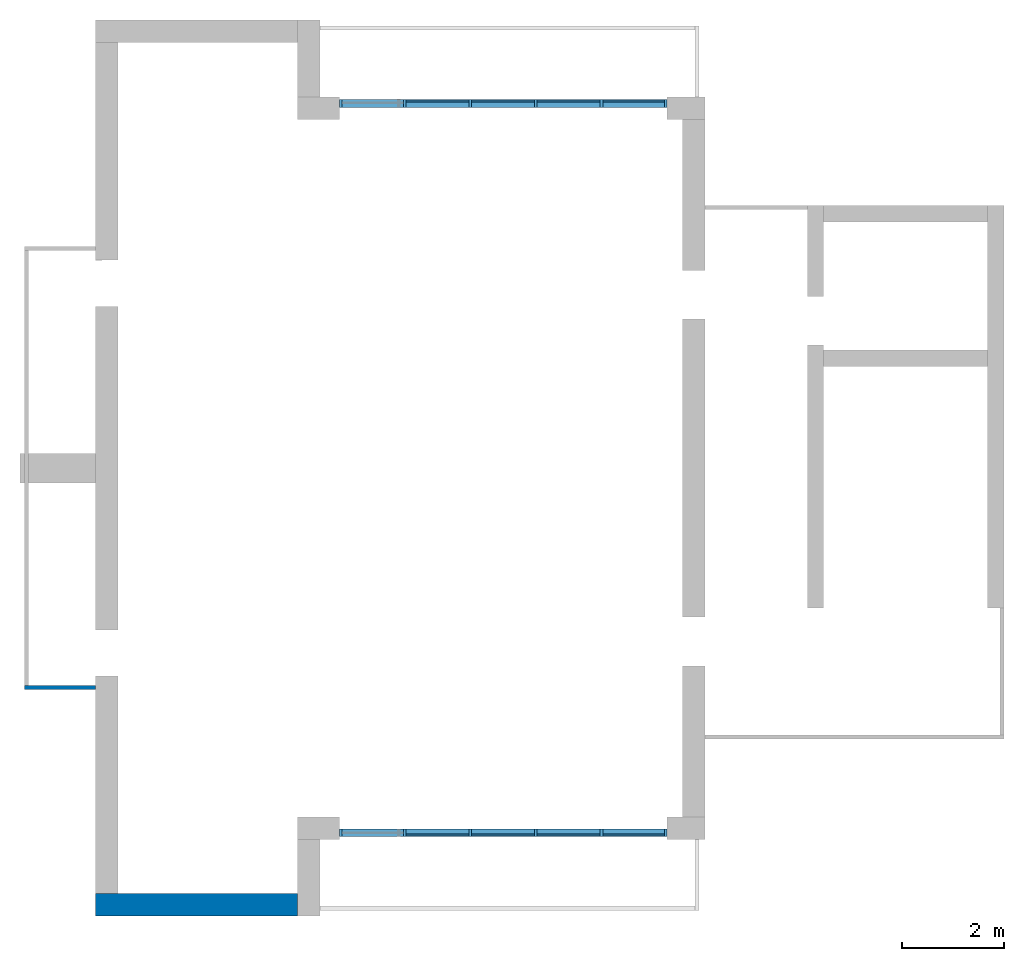
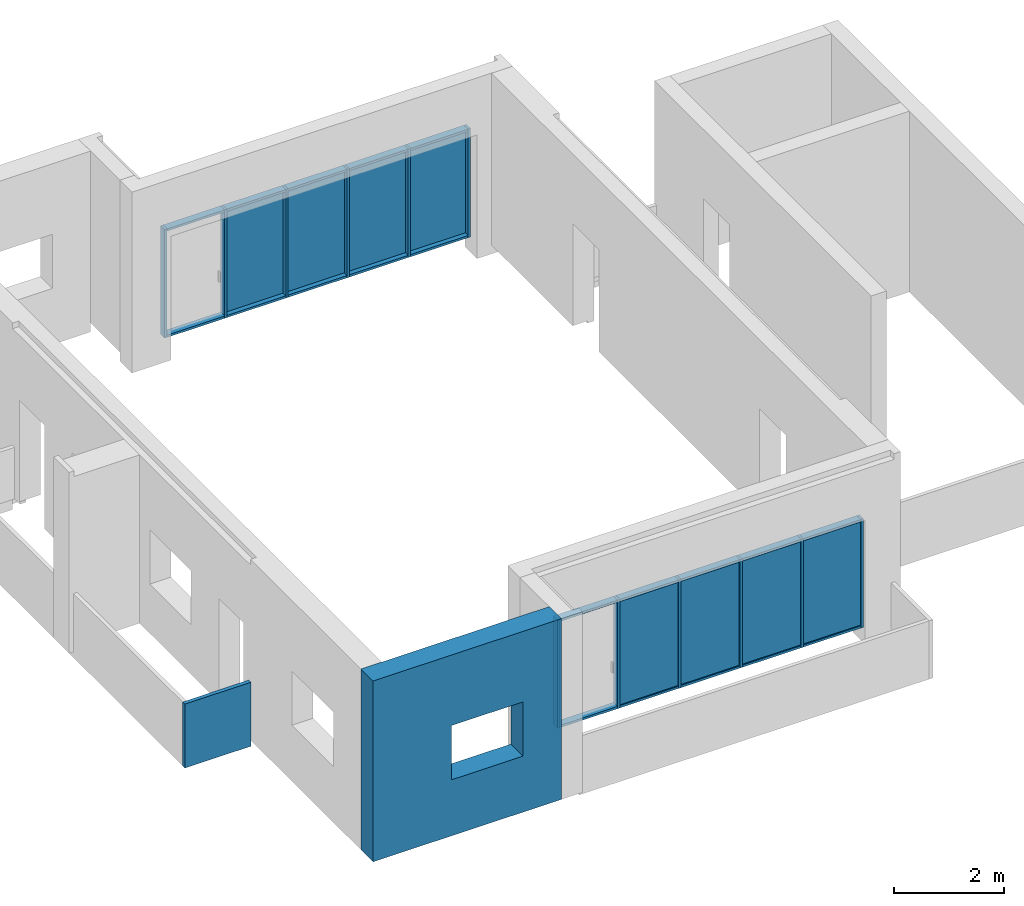
# One storey, part 1 of 4: 32 members, 8 plates, 2 walls, 1 opening, 2 elements without a shape of their own.
"""IFC2X3 building model written with IfcOpenShell, lengths in millimetres."""

from ifc_helpers import new_model, entity, si_unit, converted_unit, derived_unit, direction, frame, frame_2d, origin, origin_2d_with_axis, place, context, subcontext, project, spatial, polyline, rectangle, extrude, clip, bounded_halfspace, source, transform, mapped, material, layer, layer_set, layer_usage, type_object, type_shapes, element, aggregate, save


model = new_model("IFC2X3")

# Units and contexts
model_context = context("Model", 3, precision=0.01, world=origin(), true_north=direction((6.12303176911189e-17, 1.0)))
body_context = subcontext(model_context, "Body", "Model", "MODEL_VIEW")
ifc_project = project(units=[si_unit("LENGTHUNIT", "METRE", prefix="MILLI"), si_unit("AREAUNIT", "SQUARE_METRE"), si_unit("VOLUMEUNIT", "CUBIC_METRE"), converted_unit("PLANEANGLEUNIT", "DEGREE", entity("IfcRatioMeasure", 0.0174532925199433), si_unit("PLANEANGLEUNIT", "RADIAN"), dimensions=[0, 0, 0, 0, 0, 0, 0]), si_unit("MASSUNIT", "GRAM", prefix="KILO"), derived_unit("MASSDENSITYUNIT", [(si_unit("MASSUNIT", "GRAM", prefix="KILO"), 1), (si_unit("LENGTHUNIT", "METRE"), -3)]), si_unit("TIMEUNIT", "SECOND"), si_unit("FREQUENCYUNIT", "HERTZ"), si_unit("THERMODYNAMICTEMPERATUREUNIT", "DEGREE_CELSIUS"), derived_unit("THERMALTRANSMITTANCEUNIT", [(si_unit("MASSUNIT", "GRAM", prefix="KILO"), 1), (si_unit("THERMODYNAMICTEMPERATUREUNIT", "KELVIN"), -1), (si_unit("TIMEUNIT", "SECOND"), -3)]), derived_unit("VOLUMETRICFLOWRATEUNIT", [(si_unit("LENGTHUNIT", "METRE"), 3), (si_unit("TIMEUNIT", "SECOND"), -1)]), si_unit("ELECTRICCURRENTUNIT", "AMPERE"), si_unit("ELECTRICVOLTAGEUNIT", "VOLT"), si_unit("POWERUNIT", "WATT"), si_unit("FORCEUNIT", "NEWTON", prefix="KILO"), si_unit("ILLUMINANCEUNIT", "LUX"), si_unit("LUMINOUSFLUXUNIT", "LUMEN"), si_unit("LUMINOUSINTENSITYUNIT", "CANDELA"), derived_unit("USERDEFINED", [(si_unit("MASSUNIT", "GRAM", prefix="KILO"), -1), (si_unit("LENGTHUNIT", "METRE"), -2), (si_unit("TIMEUNIT", "SECOND"), 3), (si_unit("LUMINOUSFLUXUNIT", "LUMEN"), 1)]), derived_unit("LINEARVELOCITYUNIT", [(si_unit("LENGTHUNIT", "METRE"), 1), (si_unit("TIMEUNIT", "SECOND"), -1)]), si_unit("PRESSUREUNIT", "PASCAL"), derived_unit("USERDEFINED", [(si_unit("LENGTHUNIT", "METRE"), -2), (si_unit("MASSUNIT", "GRAM", prefix="KILO"), 1), (si_unit("TIMEUNIT", "SECOND"), -2)])], contexts=[model_context])

# Site, building, storey
site_placement = place(None, origin())
site = spatial("IfcSite", under=ifc_project, at=site_placement, CompositionType="ELEMENT")
building_placement = place(site_placement, origin())
building = spatial("IfcBuilding", under=site, at=building_placement, CompositionType="ELEMENT")
storey_placement = place(building_placement, frame((0.0, 0.0, 4000.0)))
storey = spatial("IfcBuildingStorey", under=building, at=storey_placement, Name="01 Level", CompositionType="ELEMENT", Elevation=4000.0)

# Curtain wall, members
curtain_wall_type = type_object("IfcCurtainWallType", Name="Curtain Wall", PredefinedType="NOTDEFINED")
curtain_wall_1_placement = place(storey_placement, frame((0.0, 0.0, -4000.0)))
curtain_wall_1 = element("IfcCurtainWall", 1, at=curtain_wall_1_placement, inside=storey, type_object=curtain_wall_type, Name="Curtain Wall", ObjectType="Curtain Wall")
ifc_material_1 = material(Name="Aluminium")
member_type_1 = type_object("IfcMemberType", Name="50 x 150mm", PredefinedType="MEMBER")
shared_shape_1 = source(origin(), body_context, "Body", "SweptSolid", [
    extrude(rectangle(XDim=150.0, YDim=50.0, at=origin_2d_with_axis()), frame((-25.0, 0.0, -2400.0), z_axis=(0.0, 0.0, 1.0), x_axis=(0.0, -1.0, 0.0)), (0.0, 0.0, 1.0), 2400.0),
])
type_shapes(member_type_1, [shared_shape_1])
member_1_placement = place(storey_placement, frame((21803.4900708518, -75951.2395851399, 0.0), z_axis=(0.0, 0.0, -1.0), x_axis=(-1.0, 0.0, 0.0)))
member_1 = element("IfcMember", 2, at=member_1_placement, type_object=member_type_1, material=ifc_material_1, Name="Rectangular Mullion:50 x 150mm", ObjectType="Rectangular Mullion:50 x 150mm", context=body_context, shape_type="MappedRepresentation", body=[
    mapped(shared_shape_1, transform((0.0, 0.0, 0.0), scale=1.0)),
])
member_type_2 = type_object("IfcMemberType", Name="50 x 150mm", PredefinedType="MEMBER")
shared_shape_2 = source(origin(), body_context, "Body", "SweptSolid", [
    extrude(rectangle(XDim=150.0, YDim=50.0, at=origin_2d_with_axis()), frame((0.0, 0.0, -2400.0), z_axis=(0.0, 0.0, 1.0), x_axis=(0.0, -1.0, 0.0)), (0.0, 0.0, 1.0), 2400.0),
])
type_shapes(member_type_2, [shared_shape_2])
member_2_placement = place(storey_placement, frame((23083.4900708518, -75951.2395851399, 0.0), z_axis=(0.0, 0.0, -1.0), x_axis=(-1.0, 0.0, 0.0)))
member_2 = element("IfcMember", 3, at=member_2_placement, type_object=member_type_2, material=ifc_material_1, Name="Rectangular Mullion:50 x 150mm", ObjectType="Rectangular Mullion:50 x 150mm", context=body_context, shape_type="MappedRepresentation", body=[
    mapped(shared_shape_2, transform((0.0, 0.0, 0.0), scale=1.0)),
])
member_3_placement = place(storey_placement, frame((24363.4900708518, -75951.2395851399, 0.0), z_axis=(0.0, 0.0, -1.0), x_axis=(-1.0, 0.0, 0.0)))
member_3 = element("IfcMember", 4, at=member_3_placement, type_object=member_type_2, material=ifc_material_1, Name="Rectangular Mullion:50 x 150mm", ObjectType="Rectangular Mullion:50 x 150mm", context=body_context, shape_type="MappedRepresentation", body=[
    mapped(shared_shape_2, transform((0.0, 0.0, 0.0), scale=1.0)),
])
member_4_placement = place(storey_placement, frame((25643.4900708518, -75951.2395851399, 0.0), z_axis=(0.0, 0.0, -1.0), x_axis=(-1.0, 0.0, 0.0)))
member_4 = element("IfcMember", 5, at=member_4_placement, type_object=member_type_2, material=ifc_material_1, Name="Rectangular Mullion:50 x 150mm", ObjectType="Rectangular Mullion:50 x 150mm", context=body_context, shape_type="MappedRepresentation", body=[
    mapped(shared_shape_2, transform((0.0, 0.0, 0.0), scale=1.0)),
])
member_5_placement = place(storey_placement, frame((26923.4900708518, -75951.2395851399, 0.0), z_axis=(0.0, 0.0, -1.0), x_axis=(-1.0, 0.0, 0.0)))
member_5 = element("IfcMember", 6, at=member_5_placement, type_object=member_type_2, material=ifc_material_1, Name="Rectangular Mullion:50 x 150mm", ObjectType="Rectangular Mullion:50 x 150mm", context=body_context, shape_type="MappedRepresentation", body=[
    mapped(shared_shape_2, transform((0.0, 0.0, 0.0), scale=1.0)),
])
member_type_3 = type_object("IfcMemberType", Name="50 x 150mm", PredefinedType="MEMBER")
shared_shape_3 = source(origin(), body_context, "Body", "SweptSolid", [
    extrude(rectangle(XDim=150.0, YDim=50.0, at=origin_2d_with_axis()), frame((-25.0, 0.0, -2400.0), z_axis=(0.0, 0.0, 1.0), x_axis=(0.0, -1.0, 0.0)), (0.0, 0.0, 1.0), 2400.0),
])
type_shapes(member_type_3, [shared_shape_3])
member_6_placement = place(storey_placement, frame((28203.4900708518, -75951.2395851399, 2400.0)))
member_6 = element("IfcMember", 7, at=member_6_placement, type_object=member_type_3, material=ifc_material_1, Name="Rectangular Mullion:50 x 150mm", ObjectType="Rectangular Mullion:50 x 150mm", context=body_context, shape_type="MappedRepresentation", body=[
    mapped(shared_shape_3, transform((0.0, 0.0, 0.0), scale=1.0)),
])
member_type_4 = type_object("IfcMemberType", Name="50 x 150mm", PredefinedType="MEMBER")
shared_shape_4 = source(origin(), body_context, "Body", "SweptSolid", [
    extrude(rectangle(XDim=150.0, YDim=50.0, at=origin_2d_with_axis()), frame((-25.0, 0.0, -1205.0), z_axis=(0.0, 0.0, 1.0), x_axis=(0.0, -1.0, 0.0)), (0.0, 0.0, 1.0), 1205.0),
])
type_shapes(member_type_4, [shared_shape_4])
member_7_placement = place(storey_placement, frame((26948.4900708518, -75951.2395851399, 2400.0), z_axis=(-1.0, 0.0, 0.0), x_axis=(0.0, 0.0, 1.0)))
member_7 = element("IfcMember", 8, at=member_7_placement, type_object=member_type_4, material=ifc_material_1, Name="Rectangular Mullion:50 x 150mm", ObjectType="Rectangular Mullion:50 x 150mm", context=body_context, shape_type="MappedRepresentation", body=[
    mapped(shared_shape_4, transform((0.0, 0.0, 0.0), scale=1.0)),
])
member_8_placement = place(storey_placement, frame((21853.4900708518, -75951.2395851399, 2400.0), z_axis=(-1.0, 0.0, 0.0), x_axis=(0.0, 0.0, 1.0)))
member_8 = element("IfcMember", 9, at=member_8_placement, type_object=member_type_4, material=ifc_material_1, Name="Rectangular Mullion:50 x 150mm", ObjectType="Rectangular Mullion:50 x 150mm", context=body_context, shape_type="MappedRepresentation", body=[
    mapped(shared_shape_4, transform((0.0, 0.0, 0.0), scale=1.0)),
])
member_type_5 = type_object("IfcMemberType", Name="50 x 150mm", PredefinedType="MEMBER")
shared_shape_5 = source(origin(), body_context, "Body", "SweptSolid", [
    extrude(rectangle(XDim=150.0, YDim=50.0, at=origin_2d_with_axis()), frame((-25.0, 0.0, -1230.0), z_axis=(0.0, 0.0, 1.0), x_axis=(0.0, -1.0, 0.0)), (0.0, 0.0, 1.0), 1230.0),
])
type_shapes(member_type_5, [shared_shape_5])
member_9_placement = place(storey_placement, frame((24388.4900708518, -75951.2395851399, 2400.0), z_axis=(-1.0, 0.0, 0.0), x_axis=(0.0, 0.0, 1.0)))
member_9 = element("IfcMember", 10, at=member_9_placement, type_object=member_type_5, material=ifc_material_1, Name="Rectangular Mullion:50 x 150mm", ObjectType="Rectangular Mullion:50 x 150mm", context=body_context, shape_type="MappedRepresentation", body=[
    mapped(shared_shape_5, transform((0.0, 0.0, 0.0), scale=1.0)),
])
member_10_placement = place(storey_placement, frame((25668.4900708518, -75951.2395851399, 2400.0), z_axis=(-1.0, 0.0, 0.0), x_axis=(0.0, 0.0, 1.0)))
member_10 = element("IfcMember", 11, at=member_10_placement, type_object=member_type_5, material=ifc_material_1, Name="Rectangular Mullion:50 x 150mm", ObjectType="Rectangular Mullion:50 x 150mm", context=body_context, shape_type="MappedRepresentation", body=[
    mapped(shared_shape_5, transform((0.0, 0.0, 0.0), scale=1.0)),
])
member_11_placement = place(storey_placement, frame((23108.4900708518, -75951.2395851399, 2400.0), z_axis=(-1.0, 0.0, 0.0), x_axis=(0.0, 0.0, 1.0)))
member_11 = element("IfcMember", 12, at=member_11_placement, type_object=member_type_5, material=ifc_material_1, Name="Rectangular Mullion:50 x 150mm", ObjectType="Rectangular Mullion:50 x 150mm", context=body_context, shape_type="MappedRepresentation", body=[
    mapped(shared_shape_5, transform((0.0, 0.0, 0.0), scale=1.0)),
])
member_type_6 = type_object("IfcMemberType", Name="50 x 150mm", PredefinedType="MEMBER")
shared_shape_6 = source(origin(), body_context, "Body", "SweptSolid", [
    extrude(rectangle(XDim=150.0, YDim=50.0, at=origin_2d_with_axis()), frame((-25.0, 0.0, -1230.0), z_axis=(0.0, 0.0, 1.0), x_axis=(0.0, -1.0, 0.0)), (0.0, 0.0, 1.0), 1230.0),
])
type_shapes(member_type_6, [shared_shape_6])
member_12_placement = place(storey_placement, frame((26898.4900708518, -75951.2395851399, 0.0), z_axis=(1.0, 0.0, 0.0), x_axis=(0.0, 0.0, -1.0)))
member_12 = element("IfcMember", 13, at=member_12_placement, type_object=member_type_6, material=ifc_material_1, Name="Rectangular Mullion:50 x 150mm", ObjectType="Rectangular Mullion:50 x 150mm", context=body_context, shape_type="MappedRepresentation", body=[
    mapped(shared_shape_6, transform((0.0, 0.0, 0.0), scale=1.0)),
])
member_13_placement = place(storey_placement, frame((24338.4900708518, -75951.2395851399, 0.0), z_axis=(1.0, 0.0, 0.0), x_axis=(0.0, 0.0, -1.0)))
member_13 = element("IfcMember", 14, at=member_13_placement, type_object=member_type_6, material=ifc_material_1, Name="Rectangular Mullion:50 x 150mm", ObjectType="Rectangular Mullion:50 x 150mm", context=body_context, shape_type="MappedRepresentation", body=[
    mapped(shared_shape_6, transform((0.0, 0.0, 0.0), scale=1.0)),
])
member_14_placement = place(storey_placement, frame((25618.4900708518, -75951.2395851399, 0.0), z_axis=(1.0, 0.0, 0.0), x_axis=(0.0, 0.0, -1.0)))
member_14 = element("IfcMember", 15, at=member_14_placement, type_object=member_type_6, material=ifc_material_1, Name="Rectangular Mullion:50 x 150mm", ObjectType="Rectangular Mullion:50 x 150mm", context=body_context, shape_type="MappedRepresentation", body=[
    mapped(shared_shape_6, transform((0.0, 0.0, 0.0), scale=1.0)),
])
member_type_7 = type_object("IfcMemberType", Name="50 x 150mm", PredefinedType="MEMBER")
shared_shape_7 = source(origin(), body_context, "Body", "SweptSolid", [
    extrude(rectangle(XDim=150.0, YDim=50.0, at=origin_2d_with_axis()), frame((-25.0, 0.0, -1205.0), z_axis=(0.0, 0.0, 1.0), x_axis=(0.0, -1.0, 0.0)), (0.0, 0.0, 1.0), 1205.0),
])
type_shapes(member_type_7, [shared_shape_7])
member_15_placement = place(storey_placement, frame((23058.4900708518, -75951.2395851399, 0.0), z_axis=(1.0, 0.0, 0.0), x_axis=(0.0, 0.0, -1.0)))
member_15 = element("IfcMember", 16, at=member_15_placement, type_object=member_type_7, material=ifc_material_1, Name="Rectangular Mullion:50 x 150mm", ObjectType="Rectangular Mullion:50 x 150mm", context=body_context, shape_type="MappedRepresentation", body=[
    mapped(shared_shape_7, transform((0.0, 0.0, 0.0), scale=1.0)),
])
member_16_placement = place(storey_placement, frame((28153.4900708518, -75951.2395851399, 0.0), z_axis=(1.0, 0.0, 0.0), x_axis=(0.0, 0.0, -1.0)))
member_16 = element("IfcMember", 17, at=member_16_placement, type_object=member_type_7, material=ifc_material_1, Name="Rectangular Mullion:50 x 150mm", ObjectType="Rectangular Mullion:50 x 150mm", context=body_context, shape_type="MappedRepresentation", body=[
    mapped(shared_shape_7, transform((0.0, 0.0, 0.0), scale=1.0)),
])

curtain_wall_2_placement = place(storey_placement, frame((0.0, 0.0, -4000.0)))
curtain_wall_2 = element("IfcCurtainWall", 18, at=curtain_wall_2_placement, inside=storey, type_object=curtain_wall_type, Name="Curtain Wall", ObjectType="Curtain Wall")
member_type_8 = type_object("IfcMemberType", Name="50 x 150mm", PredefinedType="MEMBER")
shared_shape_8 = source(origin(), body_context, "Body", "SweptSolid", [
    extrude(rectangle(XDim=150.0, YDim=50.0, at=origin_2d_with_axis()), frame((-25.0, 0.0, -2400.0), z_axis=(0.0, 0.0, 1.0), x_axis=(0.0, -1.0, 0.0)), (0.0, 0.0, 1.0), 2400.0),
])
type_shapes(member_type_8, [shared_shape_8])
member_17_placement = place(storey_placement, frame((21803.4900708518, -61711.23958514, 0.0), z_axis=(0.0, 0.0, -1.0), x_axis=(-1.0, 0.0, 0.0)))
member_17 = element("IfcMember", 19, at=member_17_placement, type_object=member_type_8, material=ifc_material_1, Name="Rectangular Mullion:50 x 150mm", ObjectType="Rectangular Mullion:50 x 150mm", context=body_context, shape_type="MappedRepresentation", body=[
    mapped(shared_shape_8, transform((0.0, 0.0, 0.0), scale=1.0)),
])
member_type_9 = type_object("IfcMemberType", Name="50 x 150mm", PredefinedType="MEMBER")
shared_shape_9 = source(origin(), body_context, "Body", "SweptSolid", [
    extrude(rectangle(XDim=150.0, YDim=50.0, at=origin_2d_with_axis()), frame((0.0, 0.0, -2400.0), z_axis=(0.0, 0.0, 1.0), x_axis=(0.0, -1.0, 0.0)), (0.0, 0.0, 1.0), 2400.0),
])
type_shapes(member_type_9, [shared_shape_9])
member_18_placement = place(storey_placement, frame((23083.4900708518, -61711.23958514, 0.0), z_axis=(0.0, 0.0, -1.0), x_axis=(-1.0, 0.0, 0.0)))
member_18 = element("IfcMember", 20, at=member_18_placement, type_object=member_type_9, material=ifc_material_1, Name="Rectangular Mullion:50 x 150mm", ObjectType="Rectangular Mullion:50 x 150mm", context=body_context, shape_type="MappedRepresentation", body=[
    mapped(shared_shape_9, transform((0.0, 0.0, 0.0), scale=1.0)),
])
member_19_placement = place(storey_placement, frame((24363.4900708518, -61711.23958514, 0.0), z_axis=(0.0, 0.0, -1.0), x_axis=(-1.0, 0.0, 0.0)))
member_19 = element("IfcMember", 21, at=member_19_placement, type_object=member_type_9, material=ifc_material_1, Name="Rectangular Mullion:50 x 150mm", ObjectType="Rectangular Mullion:50 x 150mm", context=body_context, shape_type="MappedRepresentation", body=[
    mapped(shared_shape_9, transform((0.0, 0.0, 0.0), scale=1.0)),
])
member_20_placement = place(storey_placement, frame((25643.4900708518, -61711.23958514, 0.0), z_axis=(0.0, 0.0, -1.0), x_axis=(-1.0, 0.0, 0.0)))
member_20 = element("IfcMember", 22, at=member_20_placement, type_object=member_type_9, material=ifc_material_1, Name="Rectangular Mullion:50 x 150mm", ObjectType="Rectangular Mullion:50 x 150mm", context=body_context, shape_type="MappedRepresentation", body=[
    mapped(shared_shape_9, transform((0.0, 0.0, 0.0), scale=1.0)),
])
member_21_placement = place(storey_placement, frame((26923.4900708518, -61711.23958514, 0.0), z_axis=(0.0, 0.0, -1.0), x_axis=(-1.0, 0.0, 0.0)))
member_21 = element("IfcMember", 23, at=member_21_placement, type_object=member_type_9, material=ifc_material_1, Name="Rectangular Mullion:50 x 150mm", ObjectType="Rectangular Mullion:50 x 150mm", context=body_context, shape_type="MappedRepresentation", body=[
    mapped(shared_shape_9, transform((0.0, 0.0, 0.0), scale=1.0)),
])
member_type_10 = type_object("IfcMemberType", Name="50 x 150mm", PredefinedType="MEMBER")
shared_shape_10 = source(origin(), body_context, "Body", "SweptSolid", [
    extrude(rectangle(XDim=150.0, YDim=50.0, at=origin_2d_with_axis()), frame((-25.0, 0.0, -2400.0), z_axis=(0.0, 0.0, 1.0), x_axis=(0.0, -1.0, 0.0)), (0.0, 0.0, 1.0), 2400.0),
])
type_shapes(member_type_10, [shared_shape_10])
member_22_placement = place(storey_placement, frame((28203.4900708519, -61711.23958514, 2400.0)))
member_22 = element("IfcMember", 24, at=member_22_placement, type_object=member_type_10, material=ifc_material_1, Name="Rectangular Mullion:50 x 150mm", ObjectType="Rectangular Mullion:50 x 150mm", context=body_context, shape_type="MappedRepresentation", body=[
    mapped(shared_shape_10, transform((0.0, 0.0, 0.0), scale=1.0)),
])
member_type_11 = type_object("IfcMemberType", Name="50 x 150mm", PredefinedType="MEMBER")
shared_shape_11 = source(origin(), body_context, "Body", "SweptSolid", [
    extrude(rectangle(XDim=150.0, YDim=50.0, at=origin_2d_with_axis()), frame((-25.0, 0.0, -1205.0), z_axis=(0.0, 0.0, 1.0), x_axis=(0.0, -1.0, 0.0)), (0.0, 0.0, 1.0), 1205.0),
])
type_shapes(member_type_11, [shared_shape_11])
member_23_placement = place(storey_placement, frame((26948.4900708518, -61711.23958514, 2400.0), z_axis=(-1.0, 0.0, 0.0), x_axis=(0.0, 0.0, 1.0)))
member_23 = element("IfcMember", 25, at=member_23_placement, type_object=member_type_11, material=ifc_material_1, Name="Rectangular Mullion:50 x 150mm", ObjectType="Rectangular Mullion:50 x 150mm", context=body_context, shape_type="MappedRepresentation", body=[
    mapped(shared_shape_11, transform((0.0, 0.0, 0.0), scale=1.0)),
])
member_24_placement = place(storey_placement, frame((21853.4900708518, -61711.23958514, 2400.0), z_axis=(-1.0, 0.0, 0.0), x_axis=(0.0, 0.0, 1.0)))
member_24 = element("IfcMember", 26, at=member_24_placement, type_object=member_type_11, material=ifc_material_1, Name="Rectangular Mullion:50 x 150mm", ObjectType="Rectangular Mullion:50 x 150mm", context=body_context, shape_type="MappedRepresentation", body=[
    mapped(shared_shape_11, transform((0.0, 0.0, 0.0), scale=1.0)),
])
member_type_12 = type_object("IfcMemberType", Name="50 x 150mm", PredefinedType="MEMBER")
shared_shape_12 = source(origin(), body_context, "Body", "SweptSolid", [
    extrude(rectangle(XDim=150.0, YDim=50.0, at=origin_2d_with_axis()), frame((-25.0, 0.0, -1230.0), z_axis=(0.0, 0.0, 1.0), x_axis=(0.0, -1.0, 0.0)), (0.0, 0.0, 1.0), 1230.0),
])
type_shapes(member_type_12, [shared_shape_12])
member_25_placement = place(storey_placement, frame((24388.4900708518, -61711.23958514, 2400.0), z_axis=(-1.0, 0.0, 0.0), x_axis=(0.0, 0.0, 1.0)))
member_25 = element("IfcMember", 27, at=member_25_placement, type_object=member_type_12, material=ifc_material_1, Name="Rectangular Mullion:50 x 150mm", ObjectType="Rectangular Mullion:50 x 150mm", context=body_context, shape_type="MappedRepresentation", body=[
    mapped(shared_shape_12, transform((0.0, 0.0, 0.0), scale=1.0)),
])
member_26_placement = place(storey_placement, frame((25668.4900708518, -61711.23958514, 2400.0), z_axis=(-1.0, 0.0, 0.0), x_axis=(0.0, 0.0, 1.0)))
member_26 = element("IfcMember", 28, at=member_26_placement, type_object=member_type_12, material=ifc_material_1, Name="Rectangular Mullion:50 x 150mm", ObjectType="Rectangular Mullion:50 x 150mm", context=body_context, shape_type="MappedRepresentation", body=[
    mapped(shared_shape_12, transform((0.0, 0.0, 0.0), scale=1.0)),
])
member_27_placement = place(storey_placement, frame((23108.4900708518, -61711.23958514, 2400.0), z_axis=(-1.0, 0.0, 0.0), x_axis=(0.0, 0.0, 1.0)))
member_27 = element("IfcMember", 29, at=member_27_placement, type_object=member_type_12, material=ifc_material_1, Name="Rectangular Mullion:50 x 150mm", ObjectType="Rectangular Mullion:50 x 150mm", context=body_context, shape_type="MappedRepresentation", body=[
    mapped(shared_shape_12, transform((0.0, 0.0, 0.0), scale=1.0)),
])
member_type_13 = type_object("IfcMemberType", Name="50 x 150mm", PredefinedType="MEMBER")
shared_shape_13 = source(origin(), body_context, "Body", "SweptSolid", [
    extrude(rectangle(XDim=150.0, YDim=50.0, at=origin_2d_with_axis()), frame((-25.0, 0.0, -1230.0), z_axis=(0.0, 0.0, 1.0), x_axis=(0.0, -1.0, 0.0)), (0.0, 0.0, 1.0), 1230.0),
])
type_shapes(member_type_13, [shared_shape_13])
member_28_placement = place(storey_placement, frame((26898.4900708518, -61711.23958514, 0.0), z_axis=(1.0, 0.0, 0.0), x_axis=(0.0, 0.0, -1.0)))
member_28 = element("IfcMember", 30, at=member_28_placement, type_object=member_type_13, material=ifc_material_1, Name="Rectangular Mullion:50 x 150mm", ObjectType="Rectangular Mullion:50 x 150mm", context=body_context, shape_type="MappedRepresentation", body=[
    mapped(shared_shape_13, transform((0.0, 0.0, 0.0), scale=1.0)),
])
member_29_placement = place(storey_placement, frame((24338.4900708518, -61711.23958514, 0.0), z_axis=(1.0, 0.0, 0.0), x_axis=(0.0, 0.0, -1.0)))
member_29 = element("IfcMember", 31, at=member_29_placement, type_object=member_type_13, material=ifc_material_1, Name="Rectangular Mullion:50 x 150mm", ObjectType="Rectangular Mullion:50 x 150mm", context=body_context, shape_type="MappedRepresentation", body=[
    mapped(shared_shape_13, transform((0.0, 0.0, 0.0), scale=1.0)),
])
member_30_placement = place(storey_placement, frame((25618.4900708519, -61711.23958514, 0.0), z_axis=(1.0, 0.0, 0.0), x_axis=(0.0, 0.0, -1.0)))
member_30 = element("IfcMember", 32, at=member_30_placement, type_object=member_type_13, material=ifc_material_1, Name="Rectangular Mullion:50 x 150mm", ObjectType="Rectangular Mullion:50 x 150mm", context=body_context, shape_type="MappedRepresentation", body=[
    mapped(shared_shape_13, transform((0.0, 0.0, 0.0), scale=1.0)),
])
member_type_14 = type_object("IfcMemberType", Name="50 x 150mm", PredefinedType="MEMBER")
shared_shape_14 = source(origin(), body_context, "Body", "SweptSolid", [
    extrude(rectangle(XDim=150.0, YDim=50.0, at=origin_2d_with_axis()), frame((-25.0, 0.0, -1205.0), z_axis=(0.0, 0.0, 1.0), x_axis=(0.0, -1.0, 0.0)), (0.0, 0.0, 1.0), 1205.0),
])
type_shapes(member_type_14, [shared_shape_14])
member_31_placement = place(storey_placement, frame((23058.4900708518, -61711.23958514, 0.0), z_axis=(1.0, 0.0, 0.0), x_axis=(0.0, 0.0, -1.0)))
member_31 = element("IfcMember", 33, at=member_31_placement, type_object=member_type_14, material=ifc_material_1, Name="Rectangular Mullion:50 x 150mm", ObjectType="Rectangular Mullion:50 x 150mm", context=body_context, shape_type="MappedRepresentation", body=[
    mapped(shared_shape_14, transform((0.0, 0.0, 0.0), scale=1.0)),
])
member_32_placement = place(storey_placement, frame((28153.4900708518, -61711.23958514, 0.0), z_axis=(1.0, 0.0, 0.0), x_axis=(0.0, 0.0, -1.0)))
member_32 = element("IfcMember", 34, at=member_32_placement, type_object=member_type_14, material=ifc_material_1, Name="Rectangular Mullion:50 x 150mm", ObjectType="Rectangular Mullion:50 x 150mm", context=body_context, shape_type="MappedRepresentation", body=[
    mapped(shared_shape_14, transform((0.0, 0.0, 0.0), scale=1.0)),
])

# Plate
ifc_material_2 = material()
ifc_layer_1 = layer(ifc_material_2, 25.0)
ifc_layer_set_1 = layer_set([ifc_layer_1], Name="System Panel:Glazed")
ifc_layer_usage_1 = layer_usage(ifc_layer_set_1, "AXIS3", "POSITIVE", 0.121391076115486)
plate_type_1 = type_object("IfcPlateType", Name="Glazed", PredefinedType="CURTAIN_PANEL", material=ifc_layer_set_1)
shared_shape_15 = source(origin(), body_context, "Body", "SweptSolid", [
    extrude(rectangle(XDim=25.0, YDim=1205.0, at=origin_2d_with_axis()), frame((602.499999999999, 12.5, 0.0), z_axis=(0.0, 0.0, 1.0), x_axis=(0.0, 1.0, 0.0)), (0.0, 0.0, 1.0), 2300.0),
])
type_shapes(plate_type_1, [shared_shape_15])
plate_1_placement = place(curtain_wall_1_placement, frame((28153.4900708518, -75975.7395851399, 4050.0), z_axis=(0.0, 0.0, 1.0), x_axis=(-1.0, 0.0, 0.0)))
plate_1 = element("IfcPlate", 35, at=plate_1_placement, type_object=plate_type_1, material=ifc_layer_usage_1, Name="System Panel:Glazed", ObjectType="System Panel:Glazed", context=body_context, shape_type="MappedRepresentation", body=[
    mapped(shared_shape_15, transform((0.0, 0.0, 0.0), scale=1.0)),
])

ifc_layer_usage_2 = layer_usage(ifc_layer_set_1, "AXIS3", "POSITIVE", 0.121391076115486)
plate_type_2 = type_object("IfcPlateType", Name="Glazed", PredefinedType="CURTAIN_PANEL", material=ifc_layer_set_1)
shared_shape_16 = source(origin(), body_context, "Body", "SweptSolid", [
    extrude(rectangle(XDim=25.0, YDim=1230.00000000001, at=origin_2d_with_axis()), frame((615.0, 12.5, 0.0), z_axis=(0.0, 0.0, 1.0), x_axis=(0.0, 1.0, 0.0)), (0.0, 0.0, 1.0), 2300.0),
])
type_shapes(plate_type_2, [shared_shape_16])
plate_2_placement = place(curtain_wall_1_placement, frame((26898.4900708518, -75975.7395851399, 4050.0), z_axis=(0.0, 0.0, 1.0), x_axis=(-1.0, 0.0, 0.0)))
plate_2 = element("IfcPlate", 36, at=plate_2_placement, type_object=plate_type_2, material=ifc_layer_usage_2, Name="System Panel:Glazed", ObjectType="System Panel:Glazed", context=body_context, shape_type="MappedRepresentation", body=[
    mapped(shared_shape_16, transform((0.0, 0.0, 0.0), scale=1.0)),
])

ifc_layer_usage_3 = layer_usage(ifc_layer_set_1, "AXIS3", "POSITIVE", 0.121391076115486)
plate_3_placement = place(curtain_wall_1_placement, frame((25618.4900708518, -75975.7395851399, 4050.0), z_axis=(0.0, 0.0, 1.0), x_axis=(-1.0, 0.0, 0.0)))
plate_3 = element("IfcPlate", 37, at=plate_3_placement, type_object=plate_type_2, material=ifc_layer_usage_3, Name="System Panel:Glazed", ObjectType="System Panel:Glazed", context=body_context, shape_type="MappedRepresentation", body=[
    mapped(shared_shape_16, transform((0.0, 0.0, 0.0), scale=1.0)),
])

ifc_layer_usage_4 = layer_usage(ifc_layer_set_1, "AXIS3", "POSITIVE", 0.121391076115486)
plate_4_placement = place(curtain_wall_1_placement, frame((24338.4900708518, -75975.7395851399, 4050.0), z_axis=(0.0, 0.0, 1.0), x_axis=(-1.0, 0.0, 0.0)))
plate_4 = element("IfcPlate", 38, at=plate_4_placement, type_object=plate_type_2, material=ifc_layer_usage_4, Name="System Panel:Glazed", ObjectType="System Panel:Glazed", context=body_context, shape_type="MappedRepresentation", body=[
    mapped(shared_shape_16, transform((0.0, 0.0, 0.0), scale=1.0)),
])

aggregate(curtain_wall_1, [plate_1, plate_2, plate_3, plate_4, member_1, member_2, member_3, member_4, member_5, member_6, member_7, member_9, member_10, member_11, member_8, member_12, member_13, member_14, member_15, member_16])

ifc_layer_usage_5 = layer_usage(ifc_layer_set_1, "AXIS3", "POSITIVE", 0.121391076115486)
plate_type_3 = type_object("IfcPlateType", Name="Glazed", PredefinedType="CURTAIN_PANEL", material=ifc_layer_set_1)
shared_shape_17 = source(origin(), body_context, "Body", "SweptSolid", [
    extrude(rectangle(XDim=25.0, YDim=1205.0, at=frame_2d((2.66453525910038e-15, 0.0), x_axis=(1.0, 0.0))), frame((602.499999999999, 12.5, 0.0), z_axis=(0.0, 0.0, 1.0), x_axis=(0.0, 1.0, 0.0)), (0.0, 0.0, 1.0), 2300.0),
])
type_shapes(plate_type_3, [shared_shape_17])
plate_5_placement = place(curtain_wall_2_placement, frame((28153.4900708518, -61661.73958514, 4050.0), z_axis=(0.0, 0.0, 1.0), x_axis=(-1.0, 0.0, 0.0)))
plate_5 = element("IfcPlate", 39, at=plate_5_placement, type_object=plate_type_3, material=ifc_layer_usage_5, Name="System Panel:Glazed", ObjectType="System Panel:Glazed", context=body_context, shape_type="MappedRepresentation", body=[
    mapped(shared_shape_17, transform((0.0, 0.0, 0.0), scale=1.0)),
])

ifc_layer_usage_6 = layer_usage(ifc_layer_set_1, "AXIS3", "POSITIVE", 0.121391076115486)
plate_type_4 = type_object("IfcPlateType", Name="Glazed", PredefinedType="CURTAIN_PANEL", material=ifc_layer_set_1)
shared_shape_18 = source(origin(), body_context, "Body", "SweptSolid", [
    extrude(rectangle(XDim=25.0, YDim=1230.0, at=frame_2d((2.66453525910038e-15, 0.0), x_axis=(1.0, 0.0))), frame((615.0, 12.5, 0.0), z_axis=(0.0, 0.0, 1.0), x_axis=(0.0, 1.0, 0.0)), (0.0, 0.0, 1.0), 2300.0),
])
type_shapes(plate_type_4, [shared_shape_18])
plate_6_placement = place(curtain_wall_2_placement, frame((26898.4900708518, -61661.73958514, 4050.0), z_axis=(0.0, 0.0, 1.0), x_axis=(-1.0, 0.0, 0.0)))
plate_6 = element("IfcPlate", 40, at=plate_6_placement, type_object=plate_type_4, material=ifc_layer_usage_6, Name="System Panel:Glazed", ObjectType="System Panel:Glazed", context=body_context, shape_type="MappedRepresentation", body=[
    mapped(shared_shape_18, transform((0.0, 0.0, 0.0), scale=1.0)),
])

ifc_layer_usage_7 = layer_usage(ifc_layer_set_1, "AXIS3", "POSITIVE", 0.121391076115486)
plate_7_placement = place(curtain_wall_2_placement, frame((25618.4900708518, -61661.73958514, 4050.0), z_axis=(0.0, 0.0, 1.0), x_axis=(-1.0, 0.0, 0.0)))
plate_7 = element("IfcPlate", 41, at=plate_7_placement, type_object=plate_type_4, material=ifc_layer_usage_7, Name="System Panel:Glazed", ObjectType="System Panel:Glazed", context=body_context, shape_type="MappedRepresentation", body=[
    mapped(shared_shape_18, transform((0.0, 0.0, 0.0), scale=1.0)),
])

ifc_layer_usage_8 = layer_usage(ifc_layer_set_1, "AXIS3", "POSITIVE", 0.121391076115486)
plate_8_placement = place(curtain_wall_2_placement, frame((24338.4900708518, -61661.73958514, 4050.0), z_axis=(0.0, 0.0, 1.0), x_axis=(-1.0, 0.0, 0.0)))
plate_8 = element("IfcPlate", 42, at=plate_8_placement, type_object=plate_type_4, material=ifc_layer_usage_8, Name="System Panel:Glazed", ObjectType="System Panel:Glazed", context=body_context, shape_type="MappedRepresentation", body=[
    mapped(shared_shape_18, transform((0.0, 0.0, 0.0), scale=1.0)),
])

aggregate(curtain_wall_2, [plate_5, plate_6, plate_7, plate_8, member_17, member_18, member_19, member_20, member_21, member_22, member_23, member_25, member_26, member_27, member_24, member_28, member_29, member_30, member_31, member_32])

# Wall, opening
ifc_material_3 = material(Name="03")
ifc_layer_2 = layer(ifc_material_3, 10.0)
ifc_material_4 = material()
ifc_layer_3 = layer(ifc_material_4, 120.0)
ifc_material_5 = material()
ifc_layer_4 = layer(ifc_material_5, 300.0)
ifc_layer_5 = layer(ifc_material_3, 10.0)
ifc_layer_set_2 = layer_set([ifc_layer_2, ifc_layer_3, ifc_layer_4, ifc_layer_5], Name="Basic Wall:00_fal+12 cm")
ifc_layer_usage_9 = layer_usage(ifc_layer_set_2, "AXIS2", "NEGATIVE", 220.0)
wall_type_1 = type_object("IfcWallType", Name="Basic Wall:00_fal+12 cm", PredefinedType="STANDARD", material=ifc_layer_set_2)
wall_1_placement = place(storey_placement, frame((20983.4900708518, -77361.2395851399, -340.0), z_axis=(0.0, 0.0, 1.0), x_axis=(-1.0, 0.0, 0.0)))
wall_1 = element("IfcWallStandardCase", 43, at=wall_1_placement, inside=storey, type_object=wall_type_1, material=ifc_layer_usage_9, Name="Basic Wall:00_fal+12 cm", ObjectType="Basic Wall:00_fal+12 cm", context=body_context, shape_type="SweptSolid", body=[
    extrude(rectangle(XDim=3940.00000000002, YDim=440.000000000004, at=frame_2d((1970.00000000001, 0.0), x_axis=(-1.0, 0.0))), origin(), (0.0, 0.0, 1.0), 4000.0),
])
opening_placement = place(wall_1_placement, frame((2300.0, 1744.0, 1240.0), z_axis=(0.0, 0.0, 1.0), x_axis=(-1.0, 0.0, 0.0)))
element("IfcOpeningElement", 44, at=opening_placement, cuts=wall_1, Name="Basic Wall:00_fal+12 cm", ObjectType="Opening", context=body_context, shape_type="SweptSolid", body=[
    extrude(rectangle(XDim=1200.0, YDim=1500.0, at=frame_2d((-1.08002495835535e-12, -5.11590769747272e-13), x_axis=(0.0, 1.0))), frame((750.0, 3048.0, 600.0), z_axis=(0.0, -1.0, 0.0), x_axis=(1.0, 0.0, 0.0)), (0.0, 0.0, 1.0), 3048.0),
])

# Wall
ifc_material_6 = material(Name="03")
ifc_layer_6 = layer(ifc_material_6, 15.0)
ifc_material_7 = material(Name="02_C40/55")
ifc_layer_7 = layer(ifc_material_7, 50.0)
ifc_layer_8 = layer(ifc_material_6, 15.0)
ifc_layer_set_3 = layer_set([ifc_layer_6, ifc_layer_7, ifc_layer_8], Name="Basic Wall:00_fal")
ifc_layer_usage_10 = layer_usage(ifc_layer_set_3, "AXIS2", "NEGATIVE", 40.0)
wall_type_2 = type_object("IfcWallType", Name="Basic Wall:00_fal", PredefinedType="STANDARD", material=ifc_layer_set_3)
wall_2_placement = place(storey_placement, frame((17043.4900708518, -73116.2395851399, -465.0), z_axis=(0.0, 0.0, 1.0), x_axis=(-1.0, 0.0, 0.0)))
element("IfcWallStandardCase", 45, at=wall_2_placement, inside=storey, type_object=wall_type_2, material=ifc_layer_usage_10, Name="Basic Wall:00_fal", ObjectType="Basic Wall:00_fal", context=body_context, shape_type="Clipping", body=[
    clip(clip(clip(extrude(rectangle(XDim=1385.00000000002, YDim=79.9999999999991, at=frame_2d((692.500000000011, 4.9737991503207e-14), x_axis=(-1.0, 0.0))), origin(), (0.0, 0.0, 1.0), 1415.0), bounded_halfspace(frame((1370.0, 25.0, 0.0), z_axis=(1.0, 0.0, 0.0), x_axis=(0.0, 0.0, 1.0)), True, frame((1370.0, 25.0, 0.0), z_axis=(1.0, 0.0, 0.0), x_axis=(0.0, 0.0, 1.0)), polyline([(0.0, 0.0), (125.0, 0.0), (275.0, 0.0), (275.0, 65.0), (0.0, 65.0), (0.0, 0.0)]))), bounded_halfspace(frame((1370.0, 25.0, 0.0), z_axis=(0.0, 1.0, 0.0), x_axis=(0.0, 0.0, 1.0)), True, frame((1370.0, 25.0, 0.0), z_axis=(0.0, 1.0, 0.0), x_axis=(0.0, 0.0, 1.0)), polyline([(0.0, 0.0), (0.0, -1370.0), (125.0, -1370.0), (275.0, -1370.0), (275.0, 0.0), (125.0, 0.0), (0.0, 0.0)]))), bounded_halfspace(frame((1370.0, 25.0, 275.0)), True, frame((1370.0, 25.0, 275.0)), polyline([(0.0, 0.0), (-1370.0, 0.0), (-1370.0, -65.0), (-65.0, -65.0), (0.0, -65.0), (0.0, 0.0)]))),
])

save(model, "model.ifc")
